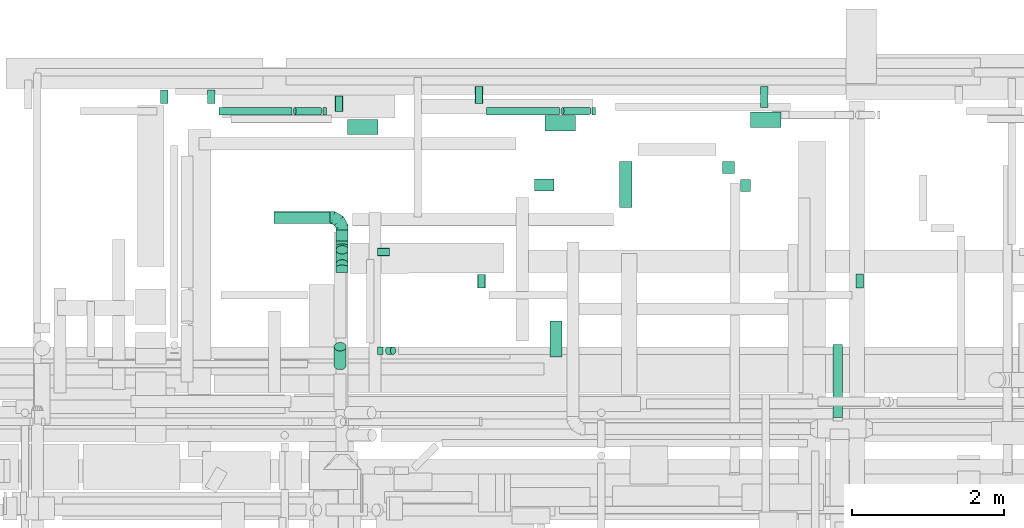
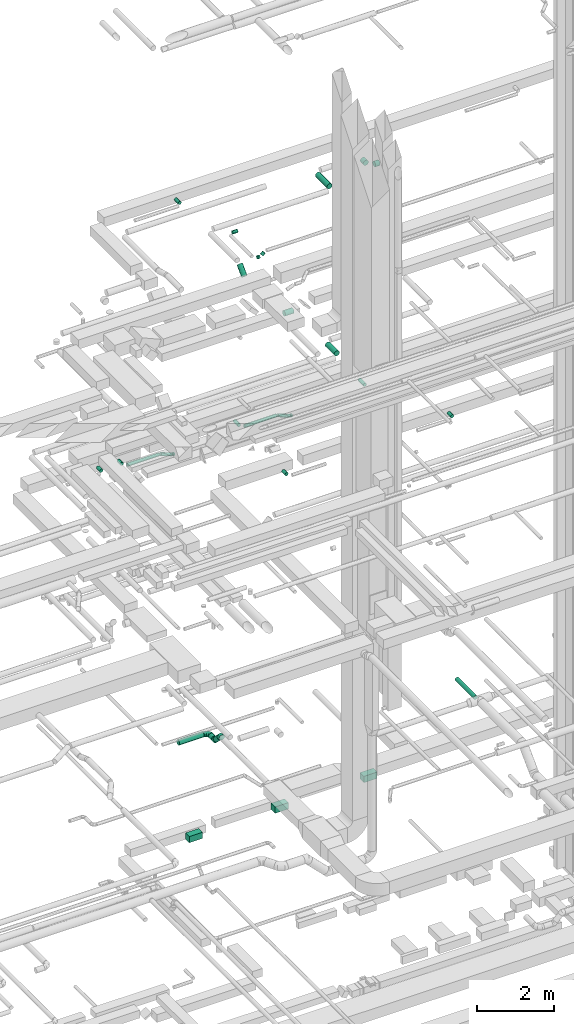
# One storey, part 153 of 337: 29 flow segments, 3 flow fittings.
"""IFC2X3 building model written with IfcOpenShell, lengths in millimetres."""

from ifc_helpers import new_model, entity, si_unit, converted_unit, derived_unit, direction, frame, origin, origin_2d_with_axis, place, context, subcontext, project, spatial, rectangle, circle, extrude, faceted_brep, source, transform, mapped, material, type_object, type_shapes, element, save


model = new_model("IFC2X3")

# Units and contexts
model_context = context("Model", 3, precision=0.01, world=origin(), true_north=direction((6.12303176911189e-17, 1.0)))
body_context = subcontext(model_context, "Body", "Model", "MODEL_VIEW")
ifc_project = project(units=[si_unit("LENGTHUNIT", "METRE", prefix="MILLI"), si_unit("AREAUNIT", "SQUARE_METRE"), si_unit("VOLUMEUNIT", "CUBIC_METRE"), converted_unit("PLANEANGLEUNIT", "DEGREE", entity("IfcRatioMeasure", 0.0174532925199433), si_unit("PLANEANGLEUNIT", "RADIAN"), dimensions=[0, 0, 0, 0, 0, 0, 0]), si_unit("MASSUNIT", "GRAM", prefix="KILO"), derived_unit("MASSDENSITYUNIT", [(si_unit("MASSUNIT", "GRAM", prefix="KILO"), 1), (si_unit("LENGTHUNIT", "METRE"), -3)]), derived_unit("MOMENTOFINERTIAUNIT", [(si_unit("LENGTHUNIT", "METRE"), 4)]), si_unit("TIMEUNIT", "SECOND"), si_unit("FREQUENCYUNIT", "HERTZ"), si_unit("THERMODYNAMICTEMPERATUREUNIT", "DEGREE_CELSIUS"), derived_unit("THERMALTRANSMITTANCEUNIT", [(si_unit("MASSUNIT", "GRAM", prefix="KILO"), 1), (si_unit("THERMODYNAMICTEMPERATUREUNIT", "KELVIN"), -1), (si_unit("TIMEUNIT", "SECOND"), -3)]), derived_unit("VOLUMETRICFLOWRATEUNIT", [(si_unit("LENGTHUNIT", "METRE"), 3), (si_unit("TIMEUNIT", "SECOND"), -1)]), derived_unit("MASSFLOWRATEUNIT", [(si_unit("MASSUNIT", "GRAM", prefix="KILO"), 1), (si_unit("TIMEUNIT", "SECOND"), -1)]), derived_unit("ROTATIONALFREQUENCYUNIT", [(si_unit("TIMEUNIT", "SECOND"), -1)]), si_unit("ELECTRICCURRENTUNIT", "AMPERE"), si_unit("ELECTRICVOLTAGEUNIT", "VOLT"), si_unit("POWERUNIT", "WATT"), si_unit("FORCEUNIT", "NEWTON", prefix="KILO"), si_unit("ILLUMINANCEUNIT", "LUX"), si_unit("LUMINOUSFLUXUNIT", "LUMEN"), si_unit("LUMINOUSINTENSITYUNIT", "CANDELA"), derived_unit("USERDEFINED", [(si_unit("MASSUNIT", "GRAM", prefix="KILO"), -1), (si_unit("LENGTHUNIT", "METRE"), -2), (si_unit("TIMEUNIT", "SECOND"), 3), (si_unit("LUMINOUSFLUXUNIT", "LUMEN"), 1)]), derived_unit("LINEARVELOCITYUNIT", [(si_unit("LENGTHUNIT", "METRE"), 1), (si_unit("TIMEUNIT", "SECOND"), -1)]), si_unit("PRESSUREUNIT", "PASCAL"), derived_unit("USERDEFINED", [(si_unit("LENGTHUNIT", "METRE"), -2), (si_unit("MASSUNIT", "GRAM", prefix="KILO"), 1), (si_unit("TIMEUNIT", "SECOND"), -2)]), derived_unit("LINEARFORCEUNIT", [(si_unit("MASSUNIT", "GRAM", prefix="KILO"), 1), (si_unit("LENGTHUNIT", "METRE"), 1), (si_unit("TIMEUNIT", "SECOND"), -2), (si_unit("LENGTHUNIT", "METRE"), -1)]), derived_unit("PLANARFORCEUNIT", [(si_unit("MASSUNIT", "GRAM", prefix="KILO"), 1), (si_unit("LENGTHUNIT", "METRE"), 1), (si_unit("TIMEUNIT", "SECOND"), -2), (si_unit("LENGTHUNIT", "METRE"), -2)])], contexts=[model_context])

# Site, building, storey
site_placement = place(None, origin())
site = spatial("IfcSite", under=ifc_project, at=site_placement, CompositionType="ELEMENT")
building_placement = place(site_placement, origin())
building = spatial("IfcBuilding", under=site, at=building_placement, CompositionType="ELEMENT")
storey_placement = place(building_placement, origin())
storey = spatial("IfcBuildingStorey", under=building, at=storey_placement, CompositionType="ELEMENT", Elevation=0.0)

# Flow segments
duct_segment_type_1 = type_object("IfcDuctSegmentType", PredefinedType="NOTDEFINED")
flow_segment_1_placement = place(storey_placement, frame((23388.02, 19098.45, -1025.0)))
element("IfcFlowSegment", 1, at=flow_segment_1_placement, inside=storey, type_object=duct_segment_type_1, context=body_context, shape_type="SweptSolid", body=[
    extrude(rectangle(XDim=195.000000000001, YDim=400.0, at=origin_2d_with_axis()), frame((200.0, 97.5, 0.0), z_axis=(0.0, 0.0, 1.0), x_axis=(0.0, -1.0, 0.0)), (0.0, 0.0, 1.0), 200.0),
])
flow_segment_2_placement = place(storey_placement, frame((25988.25, 19143.45, -1025.0)))
element("IfcFlowSegment", 2, at=flow_segment_2_placement, inside=storey, type_object=duct_segment_type_1, context=body_context, shape_type="SweptSolid", body=[
    extrude(rectangle(XDim=200.0, YDim=400.0, at=origin_2d_with_axis()), frame((200.0, 100.0, 0.0), z_axis=(0.0, 0.0, 1.0), x_axis=(0.0, -1.0, 0.0)), (0.0, 0.0, 1.0), 200.0),
])
flow_segment_3_placement = place(storey_placement, frame((28688.52, 19188.45, -1025.0)))
element("IfcFlowSegment", 3, at=flow_segment_3_placement, inside=storey, type_object=duct_segment_type_1, context=body_context, shape_type="SweptSolid", body=[
    extrude(rectangle(XDim=205.000000000001, YDim=400.0, at=origin_2d_with_axis()), frame((200.0, 102.5, 0.0), z_axis=(0.0, 0.0, 1.0), x_axis=(0.0, -1.0, 0.0)), (0.0, 0.0, 1.0), 200.0),
])
duct_segment_type_2 = type_object("IfcDuctSegmentType", PredefinedType="NOTDEFINED")
flow_segment_4_placement = place(storey_placement, frame((25217.11, 19353.19, 11348.4)))
element("IfcFlowSegment", 4, at=flow_segment_4_placement, inside=storey, type_object=duct_segment_type_2, context=body_context, shape_type="SweptSolid", body=[
    extrude(circle(Radius=50.0, at=origin_2d_with_axis()), frame((0.0, 51.6, 51.6), z_axis=(1.0, 0.0, 0.0), x_axis=(0.0, 1.0, 0.0)), (0.0, 0.0, 1.0), 960.561969086268),
])
flow_segment_5_placement = place(storey_placement, frame((22672.15, 19353.19, 11215.02)))
element("IfcFlowSegment", 5, at=flow_segment_5_placement, inside=storey, type_object=duct_segment_type_2, context=body_context, shape_type="SweptSolid", body=[
    extrude(circle(Radius=50.0, at=origin_2d_with_axis()), frame((19.51, 51.6, 178.34), z_axis=(0.933580426497202, 0.0, -0.358367949545301), x_axis=(0.0, -1.0, 0.0)), (0.0, 0.0, 1.0), 362.932191013696),
])
flow_segment_6_placement = place(storey_placement, frame((23066.33, 19353.19, 11205.06)))
element("IfcFlowSegment", 6, at=flow_segment_6_placement, inside=storey, type_object=duct_segment_type_2, context=body_context, shape_type="SweptSolid", body=[
    extrude(circle(Radius=50.0, at=origin_2d_with_axis()), frame((0.0, 51.6, 51.6), z_axis=(1.0, 0.0, 0.0), x_axis=(0.0, -1.0, 0.0)), (0.0, 0.0, 1.0), 41.4660955068436),
])
flow_segment_7_placement = place(storey_placement, frame((26194.81, 19353.19, 11201.99)))
element("IfcFlowSegment", 7, at=flow_segment_7_placement, inside=storey, type_object=duct_segment_type_2, context=body_context, shape_type="SweptSolid", body=[
    extrude(circle(Radius=50.0, at=origin_2d_with_axis()), frame((20.33, 51.6, 190.73), z_axis=(0.927183854566775, 0.0, -0.374606593415943), x_axis=(0.0, -1.0, 0.0)), (0.0, 0.0, 1.0), 381.123938172462),
])
flow_segment_8_placement = place(storey_placement, frame((26605.97, 19353.19, 11191.07)))
element("IfcFlowSegment", 8, at=flow_segment_8_placement, inside=storey, type_object=duct_segment_type_2, context=body_context, shape_type="SweptSolid", body=[
    extrude(circle(Radius=50.0, at=origin_2d_with_axis()), frame((0.0, 51.6, 51.6), z_axis=(1.0, 0.0, 0.0), x_axis=(0.0, -1.0, 0.0)), (0.0, 0.0, 1.0), 40.5619690862215),
])
flow_segment_9_placement = place(storey_placement, frame((25097.21, 17079.24, 11248.4)))
element("IfcFlowSegment", 9, at=flow_segment_9_placement, inside=storey, type_object=duct_segment_type_2, context=body_context, shape_type="SweptSolid", body=[
    extrude(circle(Radius=50.0, at=origin_2d_with_axis()), frame((51.6, 0.0, 51.6), z_axis=(-2.53517833479313e-06, 1.0, 0.0), x_axis=(1.0, 2.53517833479313e-06, 0.0)), (0.0, 0.0, 1.0), 171.664396755468),
])
flow_segment_10_placement = place(storey_placement, frame((30073.9, 17079.24, 11348.4)))
element("IfcFlowSegment", 10, at=flow_segment_10_placement, inside=storey, type_object=duct_segment_type_2, context=body_context, shape_type="SweptSolid", body=[
    extrude(circle(Radius=50.0, at=origin_2d_with_axis()), frame((51.6, 0.0, 51.6), z_axis=(0.0, 1.0, 0.0), x_axis=(1.0, 0.0, 0.0)), (0.0, 0.0, 1.0), 178.972173581738),
])
flow_segment_11_placement = place(storey_placement, frame((22415.55, 17919.98, 3088.4)))
element("IfcFlowSegment", 11, at=flow_segment_11_placement, inside=storey, type_object=duct_segment_type_2, context=body_context, shape_type="SweptSolid", body=[
    extrude(circle(Radius=80.0, at=origin_2d_with_axis()), frame((0.0, 81.6, 81.6), z_axis=(1.0, 0.0, 0.0), x_axis=(0.0, 1.0, 0.0)), (0.0, 0.0, 1.0), 740.000000000174),
])
flow_segment_12_placement = place(storey_placement, frame((23233.95, 17692.13, 3088.4)))
element("IfcFlowSegment", 12, at=flow_segment_12_placement, inside=storey, type_object=duct_segment_type_2, context=body_context, shape_type="SweptSolid", body=[
    extrude(circle(Radius=80.0, at=origin_2d_with_axis()), frame((81.6, 0.0, 81.6), z_axis=(0.0, 1.0, 0.0), x_axis=(-1.0, 0.0, 0.0)), (0.0, 0.0, 1.0), 149.445713220331),
])
flow_segment_13_placement = place(storey_placement, frame((23233.95, 17334.56, 3158.7)))
element("IfcFlowSegment", 13, at=flow_segment_13_placement, inside=storey, type_object=duct_segment_type_2, context=body_context, shape_type="SweptSolid", body=[
    extrude(circle(Radius=80.0, at=origin_2d_with_axis()), frame((81.6, 244.44, 58.16), z_axis=(0.0, -0.707106781186548, 0.707106781186547), x_axis=(-1.0, 0.0, 0.0)), (0.0, 0.0, 1.0), 263.431457505083),
])
flow_segment_14_placement = place(storey_placement, frame((29774.66, 15369.94, 3535.9)))
element("IfcFlowSegment", 14, at=flow_segment_14_placement, inside=storey, type_object=duct_segment_type_2, context=body_context, shape_type="SweptSolid", body=[
    extrude(circle(Radius=62.5, at=origin_2d_with_axis()), frame((64.1, 0.0, 64.1), z_axis=(0.0, 1.0, 0.0), x_axis=(1.0, 0.0, 0.0)), (0.0, 0.0, 1.0), 959.99999999999),
])
flow_segment_15_placement = place(storey_placement, frame((20924.47, 19504.79, 11348.4)))
element("IfcFlowSegment", 15, at=flow_segment_15_placement, inside=storey, type_object=duct_segment_type_2, context=body_context, shape_type="SweptSolid", body=[
    extrude(circle(Radius=50.0, at=origin_2d_with_axis()), frame((51.6, 0.0, 51.6), z_axis=(0.0, 1.0, 0.0), x_axis=(1.0, 0.0, 0.0)), (0.0, 0.0, 1.0), 176.269796034433),
])
flow_segment_16_placement = place(storey_placement, frame((21694.36, 19353.19, 11348.4)))
element("IfcFlowSegment", 16, at=flow_segment_16_placement, inside=storey, type_object=duct_segment_type_2, context=body_context, shape_type="SweptSolid", body=[
    extrude(circle(Radius=50.0, at=origin_2d_with_axis()), frame((0.0, 51.6, 51.6), z_axis=(1.0, 0.0, 0.0), x_axis=(0.0, 1.0, 0.0)), (0.0, 0.0, 1.0), 961.466095506868),
])
flow_segment_17_placement = place(storey_placement, frame((21542.76, 19504.79, 11348.4)))
element("IfcFlowSegment", 17, at=flow_segment_17_placement, inside=storey, type_object=duct_segment_type_2, context=body_context, shape_type="SweptSolid", body=[
    extrude(circle(Radius=50.0, at=origin_2d_with_axis()), frame((51.6, 0.0, 51.6), z_axis=(0.0, 1.0, 0.0), x_axis=(1.0, 0.0, 0.0)), (0.0, 0.0, 1.0), 176.269796034433),
])
flow_segment_18_placement = place(storey_placement, frame((25065.52, 19504.79, 11348.4)))
element("IfcFlowSegment", 18, at=flow_segment_18_placement, inside=storey, type_object=duct_segment_type_2, context=body_context, shape_type="SweptSolid", body=[
    extrude(circle(Radius=50.0, at=origin_2d_with_axis()), frame((51.6, 0.0, 51.6), z_axis=(0.0, 1.0, 0.0), x_axis=(1.0, 0.0, 0.0)), (0.0, 0.0, 1.0), 226.26979603443),
])
flow_segment_19_placement = place(storey_placement, frame((28819.83, 19452.57, 11348.4)))
element("IfcFlowSegment", 19, at=flow_segment_19_placement, inside=storey, type_object=duct_segment_type_2, context=body_context, shape_type="SweptSolid", body=[
    extrude(circle(Radius=50.0, at=origin_2d_with_axis()), frame((51.6, 0.0, 51.6), z_axis=(0.0, 1.0, 0.0), x_axis=(1.0, 0.0, 0.0)), (0.0, 0.0, 1.0), 278.488091362829),
])
flow_segment_20_placement = place(storey_placement, frame((26048.4, 16169.3, 15268.4)))
element("IfcFlowSegment", 20, at=flow_segment_20_placement, inside=storey, type_object=duct_segment_type_2, context=body_context, shape_type="SweptSolid", body=[
    extrude(circle(Radius=80.0, at=origin_2d_with_axis()), frame((81.6, 0.0, 81.6), z_axis=(0.0, 1.0, 0.0), x_axis=(1.0, 0.0, 0.0)), (0.0, 0.0, 1.0), 470.700000000016),
])
flow_segment_21_placement = place(storey_placement, frame((23222.2, 19399.86, 19118.4)))
element("IfcFlowSegment", 21, at=flow_segment_21_placement, inside=storey, type_object=duct_segment_type_2, context=body_context, shape_type="SweptSolid", body=[
    extrude(circle(Radius=50.0, at=origin_2d_with_axis()), frame((51.6, 0.0, 51.6), z_axis=(0.0, 1.0, 0.0), x_axis=(1.0, 0.0, 0.0)), (0.0, 0.0, 1.0), 205.46874999999),
])
flow_segment_22_placement = place(storey_placement, frame((26965.59, 18134.31, 19068.4)))
element("IfcFlowSegment", 22, at=flow_segment_22_placement, inside=storey, type_object=duct_segment_type_2, context=body_context, shape_type="SweptSolid", body=[
    extrude(circle(Radius=80.0, at=origin_2d_with_axis()), frame((81.6, 0.0, 81.6), z_axis=(0.0, 1.0, 0.0), x_axis=(1.0, 0.0, 0.0)), (0.0, 0.0, 1.0), 606.24999999999),
])
flow_segment_23_placement = place(storey_placement, frame((28316.52, 18585.56, 19068.4)))
element("IfcFlowSegment", 23, at=flow_segment_23_placement, inside=storey, type_object=duct_segment_type_2, context=body_context, shape_type="SweptSolid", body=[
    extrude(circle(Radius=80.0, at=origin_2d_with_axis()), frame((81.6, 0.0, 81.6), z_axis=(0.0, 1.0, 0.0), x_axis=(-1.0, 0.0, 0.0)), (0.0, 0.0, 1.0), 155.00000000003),
])
flow_segment_24_placement = place(storey_placement, frame((28558.12, 18343.97, 19068.4)))
element("IfcFlowSegment", 24, at=flow_segment_24_placement, inside=storey, type_object=duct_segment_type_2, context=body_context, shape_type="SweptSolid", body=[
    extrude(circle(Radius=80.0, at=origin_2d_with_axis()), frame((0.0, 81.6, 81.6), z_axis=(1.0, 0.0, 0.0), x_axis=(0.0, -1.0, 0.0)), (0.0, 0.0, 1.0), 133.750000000013),
])
flow_segment_25_placement = place(storey_placement, frame((23783.29, 17498.76, 19123.4)))
element("IfcFlowSegment", 25, at=flow_segment_25_placement, inside=storey, type_object=duct_segment_type_2, context=body_context, shape_type="SweptSolid", body=[
    extrude(circle(Radius=50.0, at=origin_2d_with_axis()), frame((0.0, 51.6, 51.6), z_axis=(1.0, 0.0, 0.0), x_axis=(0.0, -1.0, 0.0)), (0.0, 0.0, 1.0), 154.374999999984),
])
flow_segment_26_placement = place(storey_placement, frame((25844.94, 18348.4, 15268.4)))
element("IfcFlowSegment", 26, at=flow_segment_26_placement, inside=storey, type_object=duct_segment_type_2, context=body_context, shape_type="SweptSolid", body=[
    extrude(circle(Radius=80.0, at=origin_2d_with_axis()), frame((0.0, 81.6, 81.6), z_axis=(1.0, 0.0, 0.0), x_axis=(0.0, -1.0, 0.0)), (0.0, 0.0, 1.0), 259.999999999989),
])
flow_segment_27_placement = place(storey_placement, frame((23207.77, 15999.85, 18799.29)))
element("IfcFlowSegment", 27, at=flow_segment_27_placement, inside=storey, type_object=duct_segment_type_2, context=body_context, shape_type="SweptSolid", body=[
    extrude(circle(Radius=80.0, at=origin_2d_with_axis()), frame((81.6, 58.16, 58.16), z_axis=(0.0, 0.707106781186548, 0.707106781186548), x_axis=(-1.0, 0.0, 0.0)), (0.0, 0.0, 1.0), 347.451660040623),
])
flow_segment_28_placement = place(storey_placement, frame((23783.29, 16198.76, 19123.4)))
element("IfcFlowSegment", 28, at=flow_segment_28_placement, inside=storey, type_object=duct_segment_type_2, context=body_context, shape_type="SweptSolid", body=[
    extrude(circle(Radius=50.0, at=origin_2d_with_axis()), frame((0.0, 51.6, 51.6), z_axis=(1.0, 0.0, 0.0), x_axis=(0.0, -1.0, 0.0)), (0.0, 0.0, 1.0), 66.7986469626959),
])
flow_segment_29_placement = place(storey_placement, frame((23883.85, 16198.76, 19167.34)))
element("IfcFlowSegment", 29, at=flow_segment_29_placement, inside=storey, type_object=duct_segment_type_2, context=body_context, shape_type="SweptSolid", body=[
    extrude(circle(Radius=50.0, at=origin_2d_with_axis()), frame((36.95, 51.6, 36.95), z_axis=(0.707106781186554, 0.0, 0.707106781186541), x_axis=(0.0, -1.0, 0.0)), (0.0, 0.0, 1.0), 93.9339828220001),
])

# Flow fittings
ifc_material = material()
duct_fitting_type_1 = type_object("IfcDuctFittingType", PredefinedType="NOTDEFINED", material=ifc_material)
shared_shape_1 = source(origin(), body_context, "Body", "Brep", [
    faceted_brep([(-160.0, 0.0, -80.0), (-160.0, -20.71, -77.27), (-160.0, -40.0, -69.28), (-160.0, -56.57, -56.57), (-160.0, -69.28, -40.0), (-160.0, -77.27, -20.71), (-160.0, -80.0, 0.0), (-160.0, -77.27, 20.71), (-160.0, -69.28, 40.0), (-160.0, -56.57, 56.57), (-160.0, -40.0, 69.28), (-160.0, -20.71, 77.27), (-160.0, 0.0, 80.0), (-160.0, 20.71, 77.27), (-160.0, 40.0, 69.28), (-160.0, 56.57, 56.57), (-160.0, 69.28, 40.0), (-160.0, 77.27, 20.71), (-160.0, 80.0, 0.0), (-160.0, 77.27, -20.71), (-160.0, 69.28, -40.0), (-160.0, 56.57, -56.57), (-160.0, 40.0, -69.28), (-160.0, 20.71, -77.27), (-122.68, 20.71, 77.27), (-127.85, 40.0, 69.28), (-117.13, 0.0, 80.0), (-132.29, 56.57, 56.57), (-137.83, 77.27, 20.71), (-138.56, 80.0, 0.0), (-135.69, 69.28, 40.0), (-135.69, 69.28, -40.0), (-132.29, 56.57, -56.57), (-137.83, 77.27, -20.71), (-122.68, 20.71, -77.27), (-117.13, 0.0, -80.0), (-127.85, 40.0, -69.28), (-111.58, -20.71, -77.27), (-106.41, -40.0, -69.28), (-101.97, -56.57, -56.57), (-98.56, -69.28, -40.0), (-96.42, -77.27, -20.71), (-95.69, -80.0, 0.0), (-96.42, -77.27, 20.71), (-98.56, -69.28, 40.0), (-101.97, -56.57, 56.57), (-106.41, -40.0, 69.28), (-111.58, -20.71, 77.27), (-58.03, 58.03, 77.27), (-72.15, 72.15, 69.28), (-42.87, 42.87, 80.0), (-84.28, 84.28, 56.57), (-93.59, 93.59, 40.0), (-99.44, 99.44, 20.71), (-101.44, 101.44, 0.0), (-99.44, 99.44, -20.71), (-93.59, 93.59, -40.0), (-84.28, 84.28, -56.57), (-58.03, 58.03, -77.27), (-42.87, 42.87, -80.0), (-72.15, 72.15, -69.28), (-27.71, 27.71, -77.27), (-13.59, 13.59, -69.28), (-1.46, 1.46, -56.57), (7.85, -7.85, -40.0), (13.7, -13.7, -20.71), (15.69, -15.69, 0.0), (13.7, -13.7, 20.71), (7.85, -7.85, 40.0), (-1.46, 1.46, 56.57), (-13.59, 13.59, 69.28), (-27.71, 27.71, 77.27), (-20.71, 122.68, 77.27), (-40.0, 127.85, 69.28), (0.0, 117.13, 80.0), (-56.57, 132.29, 56.57), (-69.28, 135.69, 40.0), (-77.27, 137.83, 20.71), (-80.0, 138.56, 0.0), (-77.27, 137.83, -20.71), (-69.28, 135.69, -40.0), (-56.57, 132.29, -56.57), (-20.71, 122.68, -77.27), (0.0, 117.13, -80.0), (-40.0, 127.85, -69.28), (20.71, 111.58, -77.27), (40.0, 106.41, -69.28), (56.57, 101.97, -56.57), (69.28, 98.56, -40.0), (77.27, 96.42, -20.71), (80.0, 95.69, 0.0), (77.27, 96.42, 20.71), (69.28, 98.56, 40.0), (56.57, 101.97, 56.57), (40.0, 106.41, 69.28), (20.71, 111.58, 77.27), (-20.71, 160.0, -77.27), (-40.0, 160.0, -69.28), (-56.57, 160.0, -56.57), (-69.28, 160.0, -40.0), (-77.27, 160.0, -20.71), (-80.0, 160.0, 0.0), (-77.27, 160.0, 20.71), (-69.28, 160.0, 40.0), (-56.57, 160.0, 56.57), (-40.0, 160.0, 69.28), (-20.71, 160.0, 77.27), (0.0, 160.0, 80.0), (20.71, 160.0, 77.27), (40.0, 160.0, 69.28), (56.57, 160.0, 56.57), (69.28, 160.0, 40.0), (77.27, 160.0, 20.71), (80.0, 160.0, 0.0), (77.27, 160.0, -20.71), (69.28, 160.0, -40.0), (56.57, 160.0, -56.57), (40.0, 160.0, -69.28), (20.71, 160.0, -77.27), (0.0, 160.0, -80.0)], [[[0, 1, 2, 3, 4, 5, 6, 7, 8, 9, 10, 11, 12, 13, 14, 15, 16, 17, 18, 19, 20, 21, 22, 23]], [[24, 25, 14, 13]], [[26, 24, 13, 12]], [[14, 25, 27, 15]], [[28, 29, 18, 17]], [[30, 28, 17, 16]], [[15, 27, 30, 16]], [[20, 31, 32, 21]], [[33, 31, 20, 19]], [[18, 29, 33, 19]], [[34, 35, 0, 23]], [[36, 34, 23, 22]], [[32, 36, 22, 21]], [[1, 0, 35, 37]], [[2, 1, 37, 38]], [[3, 2, 38, 39]], [[5, 4, 40, 41]], [[6, 5, 41, 42]], [[39, 40, 4, 3]], [[6, 42, 43, 7]], [[7, 43, 44, 8]], [[8, 44, 45, 9]], [[9, 45, 46, 10]], [[10, 46, 47, 11]], [[26, 12, 11, 47]], [[48, 49, 25, 24]], [[50, 48, 24, 26]], [[27, 25, 49, 51]], [[52, 53, 28, 30]], [[51, 52, 30, 27]], [[29, 28, 53, 54]], [[55, 56, 31, 33]], [[54, 55, 33, 29]], [[32, 31, 56, 57]], [[58, 59, 35, 34]], [[60, 58, 34, 36]], [[57, 60, 36, 32]], [[37, 35, 59, 61]], [[38, 37, 61, 62]], [[39, 38, 62, 63]], [[41, 40, 64, 65]], [[42, 41, 65, 66]], [[63, 64, 40, 39]], [[43, 42, 66, 67]], [[44, 43, 67, 68]], [[68, 69, 45, 44]], [[46, 45, 69, 70]], [[47, 46, 70, 71]], [[26, 47, 71, 50]], [[72, 73, 49, 48]], [[74, 72, 48, 50]], [[51, 49, 73, 75]], [[76, 77, 53, 52]], [[75, 76, 52, 51]], [[54, 53, 77, 78]], [[79, 80, 56, 55]], [[78, 79, 55, 54]], [[57, 56, 80, 81]], [[82, 83, 59, 58]], [[84, 82, 58, 60]], [[81, 84, 60, 57]], [[61, 59, 83, 85]], [[62, 61, 85, 86]], [[63, 62, 86, 87]], [[65, 64, 88, 89]], [[66, 65, 89, 90]], [[87, 88, 64, 63]], [[67, 66, 90, 91]], [[68, 67, 91, 92]], [[92, 93, 69, 68]], [[70, 69, 93, 94]], [[71, 70, 94, 95]], [[50, 71, 95, 74]], [[96, 97, 98, 99, 100, 101, 102, 103, 104, 105, 106, 107, 108, 109, 110, 111, 112, 113, 114, 115, 116, 117, 118, 119]], [[72, 74, 107, 106]], [[73, 72, 106, 105]], [[75, 73, 105, 104]], [[77, 76, 103, 102]], [[78, 77, 102, 101]], [[75, 104, 103, 76]], [[78, 101, 100, 79]], [[79, 100, 99, 80]], [[80, 99, 98, 81]], [[84, 97, 96, 82]], [[82, 96, 119, 83]], [[84, 81, 98, 97]], [[118, 117, 86, 85]], [[119, 118, 85, 83]], [[116, 87, 86, 117]], [[88, 115, 114, 89]], [[89, 114, 113, 90]], [[115, 88, 87, 116]], [[112, 111, 92, 91]], [[113, 112, 91, 90]], [[111, 110, 93, 92]], [[95, 94, 109, 108]], [[74, 95, 108, 107]], [[110, 109, 94, 93]]]),
])
type_shapes(duct_fitting_type_1, [shared_shape_1])
flow_fitting_placement = place(storey_placement, frame((23315.55, 18001.58, 3170.0), z_axis=(0.0, 0.0, 1.0), x_axis=(0.0, 1.0, 0.0)))
element("IfcFlowFitting", 30, at=flow_fitting_placement, inside=storey, type_object=duct_fitting_type_1, material=ifc_material, context=body_context, shape_type="MappedRepresentation", body=[
    mapped(shared_shape_1, transform((0.0, 0.0, 0.0), scale=1.0)),
])
duct_fitting_type_2 = type_object("IfcDuctFittingType", PredefinedType="NOTDEFINED", material=ifc_material)
shared_shape_2 = source(origin(), body_context, "Body", "Brep", [
    faceted_brep([(-66.27, 0.0, -80.0), (-66.27, -20.71, -77.27), (-66.27, -40.0, -69.28), (-66.27, -56.57, -56.57), (-66.27, -69.28, -40.0), (-66.27, -77.27, -20.71), (-66.27, -80.0, 0.0), (-66.27, -77.27, 20.71), (-66.27, -69.28, 40.0), (-66.27, -56.57, 56.57), (-66.27, -40.0, 69.28), (-66.27, -20.71, 77.27), (-66.27, 0.0, 80.0), (-66.27, 20.71, 77.27), (-66.27, 40.0, 69.28), (-66.27, 56.57, 56.57), (-66.27, 69.28, 40.0), (-66.27, 77.27, 20.71), (-66.27, 80.0, 0.0), (-66.27, 77.27, -20.71), (-66.27, 69.28, -40.0), (-66.27, 56.57, -56.57), (-66.27, 40.0, -69.28), (-66.27, 20.71, -77.27), (-8.58, 20.71, 77.27), (-16.57, 40.0, 69.28), (0.0, 0.0, 80.0), (-23.43, 56.57, 56.57), (-28.7, 69.28, 40.0), (-32.01, 77.27, 20.71), (-33.14, 80.0, 0.0), (-32.01, 77.27, -20.71), (-28.7, 69.28, -40.0), (-23.43, 56.57, -56.57), (-8.58, 20.71, -77.27), (0.0, 0.0, -80.0), (-16.57, 40.0, -69.28), (8.58, -20.71, -77.27), (16.57, -40.0, -69.28), (23.43, -56.57, -56.57), (28.7, -69.28, -40.0), (32.01, -77.27, -20.71), (33.14, -80.0, 0.0), (32.01, -77.27, 20.71), (28.7, -69.28, 40.0), (23.43, -56.57, 56.57), (16.57, -40.0, 69.28), (8.58, -20.71, 77.27), (46.86, 46.86, 80.0), (32.22, 61.5, 77.27), (18.58, 75.15, 69.28), (6.86, 86.86, 56.57), (-2.13, 95.85, 40.0), (-7.78, 101.5, 20.71), (-9.71, 103.43, 0.0), (-7.78, 101.5, -20.71), (-2.13, 95.85, -40.0), (6.86, 86.86, -56.57), (18.58, 75.15, -69.28), (32.22, 61.5, -77.27), (46.86, 46.86, -80.0), (61.5, 32.22, -77.27), (75.15, 18.58, -69.28), (86.86, 6.86, -56.57), (95.85, -2.13, -40.0), (101.5, -7.78, -20.71), (103.43, -9.71, 0.0), (101.5, -7.78, 20.71), (95.85, -2.13, 40.0), (86.86, 6.86, 56.57), (75.15, 18.58, 69.28), (61.5, 32.22, 77.27)], [[[0, 1, 2, 3, 4, 5, 6, 7, 8, 9, 10, 11, 12, 13, 14, 15, 16, 17, 18, 19, 20, 21, 22, 23]], [[24, 25, 14, 13]], [[26, 24, 13, 12]], [[14, 25, 27, 15]], [[28, 29, 17, 16]], [[28, 16, 15, 27]], [[30, 18, 17, 29]], [[31, 32, 20, 19]], [[30, 31, 19, 18]], [[32, 33, 21, 20]], [[34, 35, 0, 23]], [[36, 34, 23, 22]], [[33, 36, 22, 21]], [[1, 0, 35, 37]], [[2, 1, 37, 38]], [[38, 39, 3, 2]], [[5, 4, 40, 41]], [[6, 5, 41, 42]], [[39, 40, 4, 3]], [[6, 42, 43, 7]], [[7, 43, 44, 8]], [[8, 44, 45, 9]], [[9, 45, 46, 10]], [[10, 46, 47, 11]], [[26, 12, 11, 47]], [[24, 26, 48, 49]], [[25, 24, 49, 50]], [[27, 25, 50, 51]], [[29, 28, 52, 53]], [[30, 29, 53, 54]], [[51, 52, 28, 27]], [[30, 54, 55, 31]], [[31, 55, 56, 32]], [[57, 33, 32, 56]], [[36, 58, 59, 34]], [[34, 59, 60, 35]], [[58, 36, 33, 57]], [[35, 60, 61, 37]], [[37, 61, 62, 38]], [[63, 39, 38, 62]], [[40, 64, 65, 41]], [[41, 65, 66, 42]], [[64, 40, 39, 63]], [[43, 42, 66, 67]], [[44, 43, 67, 68]], [[68, 69, 45, 44]], [[47, 46, 70, 71]], [[26, 47, 71, 48]], [[69, 70, 46, 45]], [[59, 58, 57, 56, 55, 54, 53, 52, 51, 50, 49, 48, 71, 70, 69, 68, 67, 66, 65, 64, 63, 62, 61, 60]]]),
])
type_shapes(duct_fitting_type_2, [shared_shape_2])
for number, where, z_axis, x_axis in (
    (31, (23315.55, 17625.86, 3170.0), (-1.0, 0.0, 0.0), (0.0, -1.0, 0.0)),
    (32, (23315.55, 17345.86, 3450.0), (1.0, 0.0, 0.0), (0.0, -0.707106781186529, 0.707106781186566)),
):
    element("IfcFlowFitting", number, at=place(storey_placement, frame(where, z_axis=z_axis, x_axis=x_axis)), inside=storey, type_object=duct_fitting_type_2, material=ifc_material, context=body_context, shape_type="MappedRepresentation", body=[
        mapped(shared_shape_2, transform((0.0, 0.0, 0.0), scale=1.0)),
    ])

save(model, "model.ifc")
